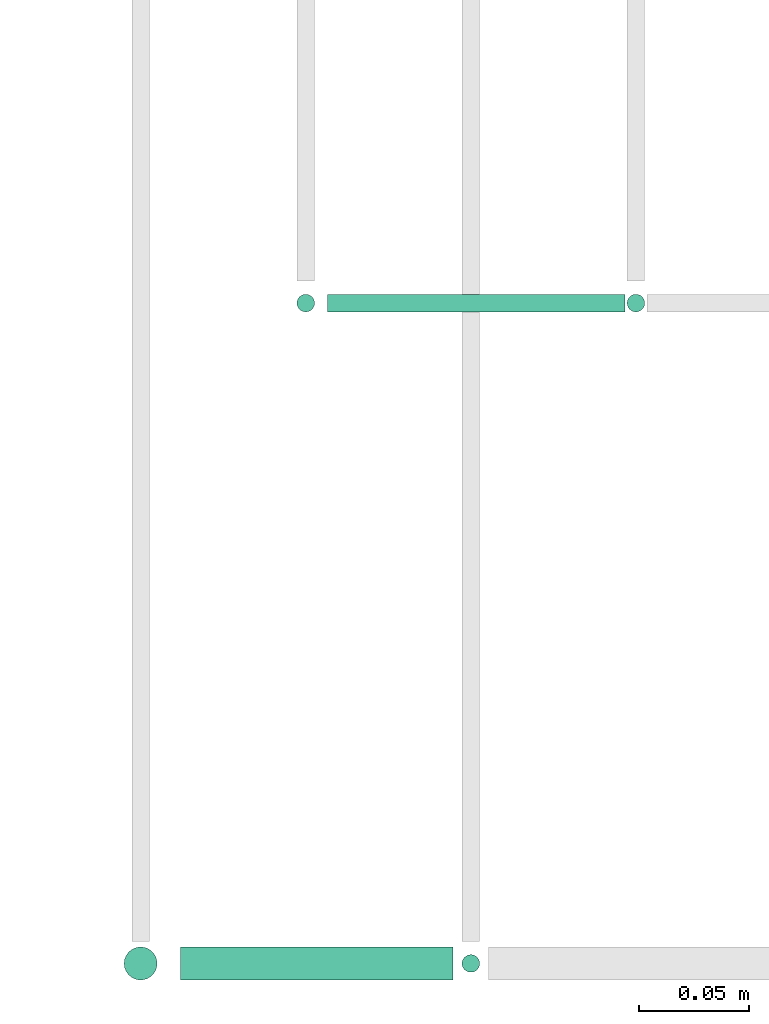
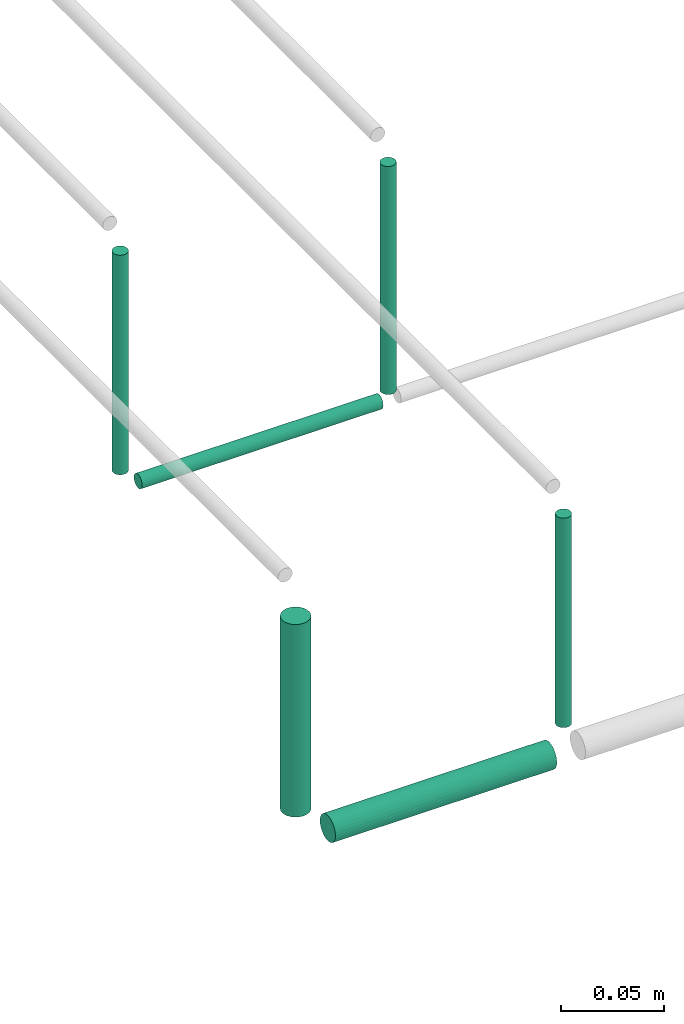
# One storey, part 39 of 89: 6 flow segments.
"""IFC2X3 building model written with IfcOpenShell, lengths in millimetres."""

from ifc_helpers import new_model, entity, si_unit, converted_unit, derived_unit, direction, frame, frame_2d, origin, origin_2d_with_axis, place, context, subcontext, project, spatial, circle, extrude, type_object, element, save


model = new_model("IFC2X3")

# Units and contexts
model_context = context("Model", 3, precision=0.01, world=origin(), true_north=direction((6.12303176911189e-17, 1.0)))
body_context = subcontext(model_context, "Body", "Model", "MODEL_VIEW")
ifc_project = project(units=[si_unit("LENGTHUNIT", "METRE", prefix="MILLI"), si_unit("AREAUNIT", "SQUARE_METRE"), si_unit("VOLUMEUNIT", "CUBIC_METRE"), converted_unit("PLANEANGLEUNIT", "DEGREE", entity("IfcRatioMeasure", 0.0174532925199433), si_unit("PLANEANGLEUNIT", "RADIAN"), dimensions=[0, 0, 0, 0, 0, 0, 0]), si_unit("MASSUNIT", "GRAM", prefix="KILO"), derived_unit("MASSDENSITYUNIT", [(si_unit("MASSUNIT", "GRAM", prefix="KILO"), 1), (si_unit("LENGTHUNIT", "METRE"), -3)]), derived_unit("MOMENTOFINERTIAUNIT", [(si_unit("LENGTHUNIT", "METRE"), 4)]), si_unit("TIMEUNIT", "SECOND"), si_unit("FREQUENCYUNIT", "HERTZ"), si_unit("THERMODYNAMICTEMPERATUREUNIT", "DEGREE_CELSIUS"), derived_unit("THERMALTRANSMITTANCEUNIT", [(si_unit("MASSUNIT", "GRAM", prefix="KILO"), 1), (si_unit("THERMODYNAMICTEMPERATUREUNIT", "KELVIN"), -1), (si_unit("TIMEUNIT", "SECOND"), -3)]), derived_unit("VOLUMETRICFLOWRATEUNIT", [(si_unit("LENGTHUNIT", "METRE"), 3), (si_unit("TIMEUNIT", "SECOND"), -1)]), derived_unit("MASSFLOWRATEUNIT", [(si_unit("MASSUNIT", "GRAM", prefix="KILO"), 1), (si_unit("TIMEUNIT", "SECOND"), -1)]), derived_unit("ROTATIONALFREQUENCYUNIT", [(si_unit("TIMEUNIT", "SECOND"), -1)]), si_unit("ELECTRICCURRENTUNIT", "AMPERE"), si_unit("ELECTRICVOLTAGEUNIT", "VOLT"), si_unit("POWERUNIT", "WATT"), si_unit("FORCEUNIT", "NEWTON", prefix="KILO"), si_unit("ILLUMINANCEUNIT", "LUX"), si_unit("LUMINOUSFLUXUNIT", "LUMEN"), si_unit("LUMINOUSINTENSITYUNIT", "CANDELA"), derived_unit("USERDEFINED", [(si_unit("MASSUNIT", "GRAM", prefix="KILO"), -1), (si_unit("LENGTHUNIT", "METRE"), -2), (si_unit("TIMEUNIT", "SECOND"), 3), (si_unit("LUMINOUSFLUXUNIT", "LUMEN"), 1)]), derived_unit("LINEARVELOCITYUNIT", [(si_unit("LENGTHUNIT", "METRE"), 1), (si_unit("TIMEUNIT", "SECOND"), -1)]), si_unit("PRESSUREUNIT", "PASCAL"), derived_unit("USERDEFINED", [(si_unit("LENGTHUNIT", "METRE"), -2), (si_unit("MASSUNIT", "GRAM", prefix="KILO"), 1), (si_unit("TIMEUNIT", "SECOND"), -2)]), derived_unit("LINEARFORCEUNIT", [(si_unit("MASSUNIT", "GRAM", prefix="KILO"), 1), (si_unit("LENGTHUNIT", "METRE"), 1), (si_unit("TIMEUNIT", "SECOND"), -2), (si_unit("LENGTHUNIT", "METRE"), -1)]), derived_unit("PLANARFORCEUNIT", [(si_unit("MASSUNIT", "GRAM", prefix="KILO"), 1), (si_unit("LENGTHUNIT", "METRE"), 1), (si_unit("TIMEUNIT", "SECOND"), -2), (si_unit("LENGTHUNIT", "METRE"), -2)])], contexts=[model_context])

# Site, building, storey
site_placement = place(None, frame((0.0, -0.00077364408347762, 0.0)))
site = spatial("IfcSite", under=ifc_project, at=site_placement, CompositionType="ELEMENT")
building_placement = place(site_placement, origin())
building = spatial("IfcBuilding", under=site, at=building_placement, CompositionType="ELEMENT")
storey_placement = place(building_placement, frame((0.0, 0.0, 24000.0)))
storey = spatial("IfcBuildingStorey", under=building, at=storey_placement, CompositionType="ELEMENT", Elevation=24000.0)

# Flow segments
pipe_segment_type = type_object("IfcPipeSegmentType", PredefinedType="NOTDEFINED")
flow_segment_1_placement = place(storey_placement, frame((42055.1085348189, 1469.35602729994, 2994.4047277641)))
element("IfcFlowSegment", 1, at=flow_segment_1_placement, inside=storey, type_object=pipe_segment_type, context=body_context, shape_type="SweptSolid", body=[
    extrude(circle(Radius=4.0, at=frame_2d((1.08286712929839e-12, 0.0), x_axis=(1.0, 0.0))), frame((0.0, 5.59527223591689, 5.59527223591499), z_axis=(1.0, 0.0, 0.0), x_axis=(0.0, 1.0, 0.0)), (0.0, 0.0, 1.0), 135.000000000004),
])
flow_segment_2_placement = place(storey_placement, frame((42039.513262583, 1469.35602729994, 3010.0)))
element("IfcFlowSegment", 2, at=flow_segment_2_placement, inside=storey, type_object=pipe_segment_type, context=body_context, shape_type="SweptSolid", body=[
    extrude(circle(Radius=4.0, at=frame_2d((0.0, 2.70716782324598e-13), x_axis=(1.0, 0.0))), frame((5.59527223591499, 5.59527223591607, 0.0), z_axis=(0.0, 0.0, 1.0), x_axis=(-1.0, 0.0, 0.0)), (0.0, 0.0, 1.0), 129.999999999988),
])
flow_segment_3_placement = place(storey_placement, frame((41961.013262583, 1165.8560272999, 3018.0)))
element("IfcFlowSegment", 3, at=flow_segment_3_placement, inside=storey, type_object=pipe_segment_type, context=body_context, shape_type="SweptSolid", body=[
    extrude(circle(Radius=7.5, at=frame_2d((0.0, 1.35358391162299e-13), x_axis=(1.0, 0.0))), frame((9.09527223591419, 9.09527223591595, 0.0)), (0.0, 0.0, 1.0), 114.000000000004),
])
flow_segment_4_placement = place(storey_placement, frame((42114.513262583, 1169.35602729991, 3016.0)))
element("IfcFlowSegment", 4, at=flow_segment_4_placement, inside=storey, type_object=pipe_segment_type, context=body_context, shape_type="SweptSolid", body=[
    extrude(circle(Radius=4.0, at=origin_2d_with_axis()), frame((5.59527223591499, 5.59527223591607, 0.0), z_axis=(0.0, 0.0, 1.0), x_axis=(-1.0, 0.0, 0.0)), (0.0, 0.0, 1.0), 124.000000000015),
])
flow_segment_5_placement = place(storey_placement, frame((41988.1085348189, 1165.8560272999, 2990.90472776407)))
element("IfcFlowSegment", 5, at=flow_segment_5_placement, inside=storey, type_object=pipe_segment_type, context=body_context, shape_type="SweptSolid", body=[
    extrude(circle(Radius=7.5, at=origin_2d_with_axis()), frame((0.0, 9.09527223591609, 9.09527223591419), z_axis=(1.0, 0.0, 0.0), x_axis=(0.0, -1.0, 0.0)), (0.0, 0.0, 1.0), 124.000000000006),
])
flow_segment_6_placement = place(storey_placement, frame((42189.513262583, 1469.35602729994, 3005.0)))
element("IfcFlowSegment", 6, at=flow_segment_6_placement, inside=storey, type_object=pipe_segment_type, context=body_context, shape_type="SweptSolid", body=[
    extrude(circle(Radius=4.0, at=origin_2d_with_axis()), frame((5.59527223591499, 5.5952722359158, 0.0), z_axis=(0.0, 0.0, 1.0), x_axis=(-1.0, 0.0, 0.0)), (0.0, 0.0, 1.0), 134.999999999987),
])

save(model, "model.ifc")
